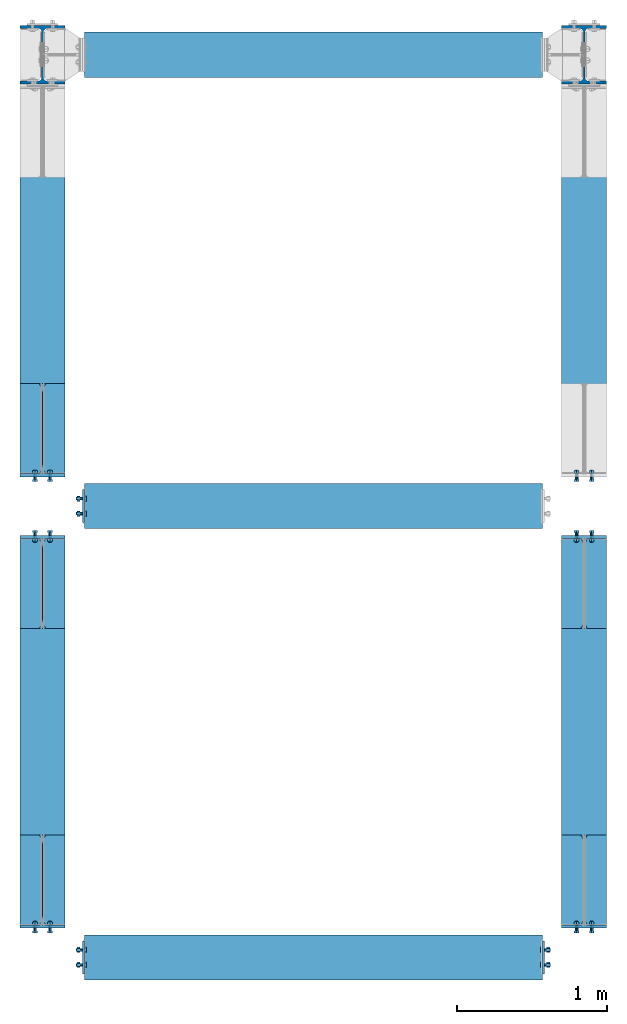
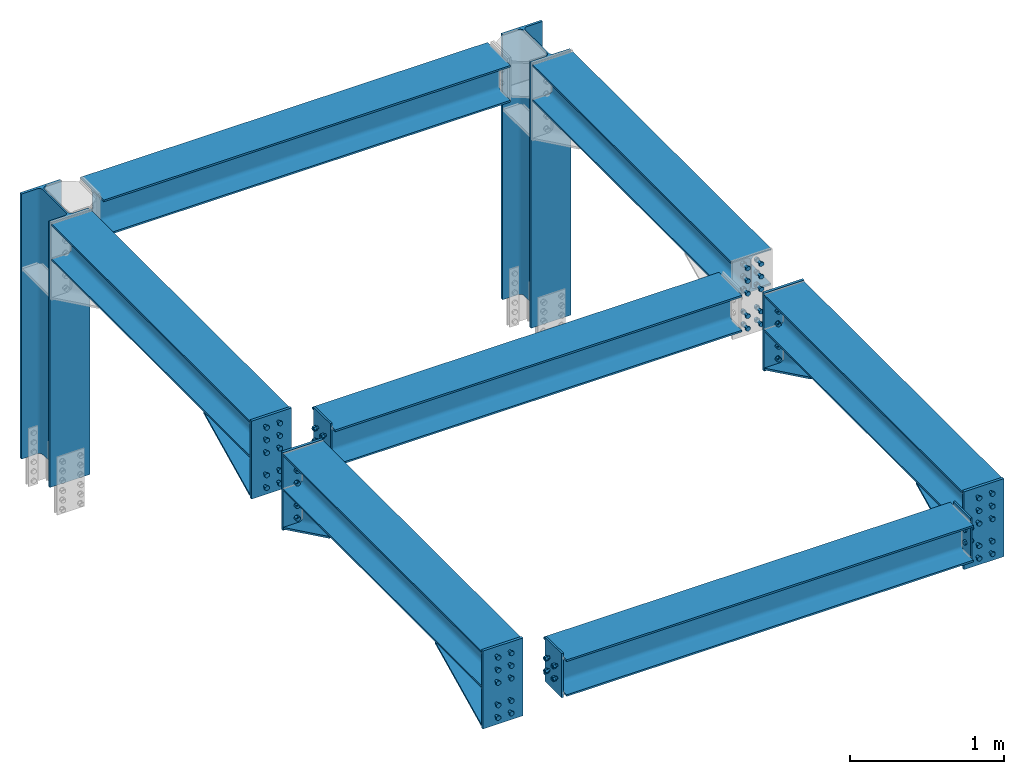
# One storey, part 1 of 11: 15 mechanical fasteners, 13 discrete accessories, 7 beams, 2 columns, 9 elements without a shape of their own.
"""IFC2X3 building model written with IfcOpenShell, lengths in millimetres."""

from ifc_helpers import new_model, si_unit, frame, origin_with_axes, origin_2d_with_axis, place, context, subcontext, project, spatial, polyline, circle, i_section, outline, extrude, clip, halfspace, source, transform, mapped, material, type_object, element, aggregate, save


model = new_model("IFC2X3")

# Units and contexts
model_context = context("Model", 3, precision=1e-05, world=origin_with_axes())
body_context = subcontext(model_context, "Body", "Model", "MODEL_VIEW")
ifc_project = project(units=[si_unit("LENGTHUNIT", "METRE", prefix="MILLI"), si_unit("AREAUNIT", "SQUARE_METRE"), si_unit("VOLUMEUNIT", "CUBIC_METRE"), si_unit("MASSUNIT", "GRAM", prefix="KILO"), si_unit("TIMEUNIT", "SECOND"), si_unit("PLANEANGLEUNIT", "RADIAN"), si_unit("SOLIDANGLEUNIT", "STERADIAN"), si_unit("THERMODYNAMICTEMPERATUREUNIT", "DEGREE_CELSIUS"), si_unit("LUMINOUSINTENSITYUNIT", "LUMEN")], contexts=[model_context])

# Site, building, storey
site_placement = place(None, origin_with_axes())
site = spatial("IfcSite", under=ifc_project, at=site_placement, CompositionType="ELEMENT")
building_placement = place(site_placement, origin_with_axes())
building = spatial("IfcBuilding", under=site, at=building_placement, Name="Edificio", CompositionType="ELEMENT")
storey_placement = place(building_placement, frame((0.0, 0.0, 3600.0), z_axis=(0.0, 0.0, 1.0), x_axis=(1.0, 0.0, 0.0)))
storey = spatial("IfcBuildingStorey", under=building, at=storey_placement, Name="Livello 2", CompositionType="ELEMENT", Elevation=3600.0)

# Assembly, column
assembly_1_placement = place(storey_placement, origin_with_axes())
assembly_1 = element("IfcElementAssembly", 1, at=assembly_1_placement, inside=storey, Name="COLUMN", AssemblyPlace="NOTDEFINED", PredefinedType="RIGID_FRAME")
ifc_material_1 = material(Name="STEEL/S235JR")
column_type = type_object("IfcColumnType", Name="HEA400", PredefinedType="NOTDEFINED")
column_1_placement = place(assembly_1_placement, frame((0.0, 6000.0, 1502.11580360386), z_axis=(0.0, 0.0, 1.0), x_axis=(0.0, 1.0, 0.0)))
column_1 = element("IfcColumn", 2, at=column_1_placement, type_object=column_type, material=ifc_material_1, Name="COLUMN", ObjectType="HEA400", context=body_context, shape_type="Clipping", body=[
    clip(extrude(i_section(OverallWidth=300.0, OverallDepth=390.0, WebThickness=11.0, FlangeThickness=19.0, FilletRadius=27.0, at=origin_2d_with_axis()), frame((0.0, 0.0, 2097.88419639614), z_axis=(0.0, 0.0, -1.0), x_axis=(0.0, 1.0, 0.0)), (0.0, 0.0, 1.0), 2097.88), halfspace(frame((1000.0, 0.0, 0.0), z_axis=(0.0, 0.0, -1.0), x_axis=(0.0, 1.0, 0.0)), False)),
])
aggregate(assembly_1, [column_1])

assembly_2_placement = place(storey_placement, origin_with_axes())
assembly_2 = element("IfcElementAssembly", 3, at=assembly_2_placement, inside=storey, Name="COLUMN", AssemblyPlace="NOTDEFINED", PredefinedType="RIGID_FRAME")
column_2_placement = place(assembly_2_placement, frame((3600.0, 6000.0, 1502.11580360386), z_axis=(0.0, 0.0, 1.0), x_axis=(0.0, 1.0, 0.0)))
column_2 = element("IfcColumn", 4, at=column_2_placement, type_object=column_type, material=ifc_material_1, Name="COLUMN", ObjectType="HEA400", context=body_context, shape_type="Clipping", body=[
    clip(extrude(i_section(OverallWidth=300.0, OverallDepth=390.0, WebThickness=11.0, FlangeThickness=19.0, FilletRadius=27.0, at=origin_2d_with_axis()), frame((0.0, 0.0, 2097.88419639614), z_axis=(0.0, 0.0, -1.0), x_axis=(0.0, 1.0, 0.0)), (0.0, 0.0, 1.0), 2097.88), halfspace(frame((1000.0, 0.0, 0.0), z_axis=(0.0, 0.0, -1.0), x_axis=(0.0, 1.0, 0.0)), False)),
])
aggregate(assembly_2, [column_2])

# Assembly, beam
assembly_3_placement = place(storey_placement, origin_with_axes())
assembly_3 = element("IfcElementAssembly", 5, at=assembly_3_placement, inside=storey, Name="BEAM", AssemblyPlace="NOTDEFINED", PredefinedType="RIGID_FRAME")
beam_type = type_object("IfcBeamType", Name="HEA300", PredefinedType="NOTDEFINED")
beam_1_placement = place(assembly_3_placement, frame((0.0, 3000.0, 3455.0), z_axis=(0.0, 0.0, 1.0), x_axis=(0.0, -1.0, 0.0)))
beam_1 = element("IfcBeam", 6, at=beam_1_placement, type_object=beam_type, material=ifc_material_1, Name="BEAM", ObjectType="HEA300", context=body_context, shape_type="Clipping", body=[
    clip(clip(extrude(i_section(OverallWidth=300.0, OverallDepth=290.0, WebThickness=8.5, FlangeThickness=14.0, FilletRadius=27.0, at=origin_2d_with_axis()), frame((2785.0, 0.0, 0.0), z_axis=(-1.0, 0.0, 0.0), x_axis=(0.0, -1.0, 0.0)), (0.0, 0.0, 1.0), 2570.0), halfspace(frame((2785.0, 0.0, -145.0), z_axis=(-1.0, 0.0, 0.0), x_axis=(0.0, 1.0, 0.0)), True)), halfspace(frame((215.0, 0.0, -145.0), z_axis=(1.0, 0.0, 0.0), x_axis=(0.0, -1.0, 0.0)), True)),
])

assembly_4_placement = place(storey_placement, origin_with_axes())
assembly_4 = element("IfcElementAssembly", 7, at=assembly_4_placement, inside=storey, Name="BEAM", AssemblyPlace="NOTDEFINED", PredefinedType="RIGID_FRAME")
beam_2_placement = place(assembly_4_placement, frame((3600.0, 3000.0, 3455.0), z_axis=(0.0, 0.0, 1.0), x_axis=(0.0, -1.0, 0.0)))
beam_2 = element("IfcBeam", 8, at=beam_2_placement, type_object=beam_type, material=ifc_material_1, Name="BEAM", ObjectType="HEA300", context=body_context, shape_type="Clipping", body=[
    clip(clip(extrude(i_section(OverallWidth=300.0, OverallDepth=290.0, WebThickness=8.5, FlangeThickness=14.0, FilletRadius=27.0, at=origin_2d_with_axis()), frame((2785.0, 0.0, 0.0), z_axis=(-1.0, 0.0, 0.0), x_axis=(0.0, -1.0, 0.0)), (0.0, 0.0, 1.0), 2570.0), halfspace(frame((2785.0, 0.0, -145.0), z_axis=(-1.0, 0.0, 0.0), x_axis=(0.0, 1.0, 0.0)), True)), halfspace(frame((215.0, 0.0, -145.0), z_axis=(1.0, 0.0, 0.0), x_axis=(0.0, -1.0, 0.0)), True)),
])

assembly_5_placement = place(storey_placement, origin_with_axes())
assembly_5 = element("IfcElementAssembly", 9, at=assembly_5_placement, inside=storey, Name="BEAM", AssemblyPlace="NOTDEFINED", PredefinedType="RIGID_FRAME")
beam_3_placement = place(assembly_5_placement, frame((0.0, 6000.0, 3455.0), z_axis=(0.0, 0.0, 1.0), x_axis=(0.0, -1.0, 0.0)))
beam_3 = element("IfcBeam", 10, at=beam_3_placement, type_object=beam_type, material=ifc_material_1, Name="BEAM", ObjectType="HEA300", context=body_context, shape_type="Clipping", body=[
    clip(clip(extrude(i_section(OverallWidth=300.0, OverallDepth=290.0, WebThickness=8.5, FlangeThickness=14.0, FilletRadius=27.0, at=origin_2d_with_axis()), frame((2785.0, 0.0, 0.0), z_axis=(-1.0, 0.0, 0.0), x_axis=(0.0, -1.0, 0.0)), (0.0, 0.0, 1.0), 2570.0), halfspace(frame((2785.0, 0.0, -145.0), z_axis=(-1.0, 0.0, 0.0), x_axis=(0.0, 1.0, 0.0)), True)), halfspace(frame((215.0, 0.0, -145.0), z_axis=(1.0, 0.0, 0.0), x_axis=(0.0, -1.0, 0.0)), True)),
])

assembly_6_placement = place(storey_placement, origin_with_axes())
assembly_6 = element("IfcElementAssembly", 11, at=assembly_6_placement, inside=storey, Name="BEAM", AssemblyPlace="NOTDEFINED", PredefinedType="RIGID_FRAME")
beam_4_placement = place(assembly_6_placement, frame((3600.0, 6000.0, 3455.0), z_axis=(0.0, 0.0, 1.0), x_axis=(0.0, -1.0, 0.0)))
beam_4 = element("IfcBeam", 12, at=beam_4_placement, type_object=beam_type, material=ifc_material_1, Name="BEAM", ObjectType="HEA300", context=body_context, shape_type="Clipping", body=[
    clip(clip(extrude(i_section(OverallWidth=300.0, OverallDepth=290.0, WebThickness=8.5, FlangeThickness=14.0, FilletRadius=27.0, at=origin_2d_with_axis()), frame((2785.0, 0.0, 0.0), z_axis=(-1.0, 0.0, 0.0), x_axis=(0.0, -1.0, 0.0)), (0.0, 0.0, 1.0), 2570.0), halfspace(frame((2785.0, 0.0, -145.0), z_axis=(-1.0, 0.0, 0.0), x_axis=(0.0, 1.0, 0.0)), True)), halfspace(frame((215.0, 0.0, -145.0), z_axis=(1.0, 0.0, 0.0), x_axis=(0.0, -1.0, 0.0)), True)),
])

assembly_7_placement = place(storey_placement, origin_with_axes())
assembly_7 = element("IfcElementAssembly", 13, at=assembly_7_placement, inside=storey, Name="BEAM", AssemblyPlace="NOTDEFINED", PredefinedType="RIGID_FRAME")
beam_5_placement = place(assembly_7_placement, frame((0.0, 6000.0, 3455.0), z_axis=(0.0, 0.0, 1.0), x_axis=(1.0, 0.0, 0.0)))
beam_5 = element("IfcBeam", 14, at=beam_5_placement, type_object=beam_type, material=ifc_material_1, Name="BEAM", ObjectType="HEA300", context=body_context, shape_type="Clipping", body=[
    clip(clip(extrude(i_section(OverallWidth=300.0, OverallDepth=290.0, WebThickness=8.5, FlangeThickness=14.0, FilletRadius=27.0, at=origin_2d_with_axis()), frame((3322.0, 0.0, 0.0), z_axis=(-1.0, 0.0, 0.0), x_axis=(0.0, -1.0, 0.0)), (0.0, 0.0, 1.0), 3044.0), halfspace(frame((3322.0, -150.0, 0.0), z_axis=(1.0, 0.0, 0.0), x_axis=(0.0, 0.0, 1.0)), False)), halfspace(frame((278.0, 150.0, 0.0), z_axis=(-1.0, 0.0, 0.0), x_axis=(0.0, 0.0, 1.0)), False)),
])
aggregate(assembly_7, [beam_5])

assembly_8_placement = place(storey_placement, origin_with_axes())
assembly_8 = element("IfcElementAssembly", 15, at=assembly_8_placement, inside=storey, Name="BEAM", AssemblyPlace="NOTDEFINED", PredefinedType="RIGID_FRAME")
beam_6_placement = place(assembly_8_placement, frame((0.0, 3000.0, 3455.0), z_axis=(0.0, 0.0, 1.0), x_axis=(1.0, 0.0, 0.0)))
beam_6 = element("IfcBeam", 16, at=beam_6_placement, type_object=beam_type, material=ifc_material_1, Name="BEAM", ObjectType="HEA300", context=body_context, shape_type="Clipping", body=[
    clip(clip(extrude(i_section(OverallWidth=300.0, OverallDepth=290.0, WebThickness=8.5, FlangeThickness=14.0, FilletRadius=27.0, at=origin_2d_with_axis()), frame((3322.0, 0.0, 0.0), z_axis=(-1.0, 0.0, 0.0), x_axis=(0.0, -1.0, 0.0)), (0.0, 0.0, 1.0), 3044.0), halfspace(frame((3322.0, -150.0, 0.0), z_axis=(1.0, 0.0, 0.0), x_axis=(0.0, 0.0, 1.0)), False)), halfspace(frame((278.0, 150.0, 0.0), z_axis=(-1.0, 0.0, 0.0), x_axis=(0.0, 0.0, 1.0)), False)),
])

assembly_9_placement = place(storey_placement, origin_with_axes())
assembly_9 = element("IfcElementAssembly", 17, at=assembly_9_placement, inside=storey, Name="BEAM", AssemblyPlace="NOTDEFINED", PredefinedType="RIGID_FRAME")
beam_7_placement = place(assembly_9_placement, frame((0.0, 0.0, 3455.0), z_axis=(0.0, 0.0, 1.0), x_axis=(1.0, 0.0, 0.0)))
beam_7 = element("IfcBeam", 18, at=beam_7_placement, type_object=beam_type, material=ifc_material_1, Name="BEAM", ObjectType="HEA300", context=body_context, shape_type="Clipping", body=[
    clip(clip(extrude(i_section(OverallWidth=300.0, OverallDepth=290.0, WebThickness=8.5, FlangeThickness=14.0, FilletRadius=27.0, at=origin_2d_with_axis()), frame((3322.0, 0.0, 0.0), z_axis=(-1.0, 0.0, 0.0), x_axis=(0.0, -1.0, 0.0)), (0.0, 0.0, 1.0), 3044.0), halfspace(frame((3322.0, -150.0, 0.0), z_axis=(1.0, 0.0, 0.0), x_axis=(0.0, 0.0, 1.0)), False)), halfspace(frame((278.0, 150.0, 0.0), z_axis=(-1.0, 0.0, 0.0), x_axis=(0.0, 0.0, 1.0)), False)),
])

# Discrete accessory
discrete_accessory_type_1 = type_object("IfcDiscreteAccessoryType", Name="PIATTO")
discrete_accessory_1_placement = place(assembly_4_placement, frame((3600.0, 2794.99999999989, 2993.20494914494), z_axis=(0.0, -1.0, 0.0), x_axis=(0.0, 0.0, 1.0)))
discrete_accessory_1 = element("IfcDiscreteAccessory", 19, at=discrete_accessory_1_placement, type_object=discrete_accessory_type_1, material=ifc_material_1, Name="PIATTO", context=body_context, shape_type="SweptSolid", body=[
    extrude(outline(polyline([(0.0, 150.0), (616.795050854866, 150.0), (616.795050854866, -150.0), (0.0, -150.0), (0.0, 150.0)])), frame((0.0, 0.0, -10.0), z_axis=(0.0, 0.0, 1.0), x_axis=(1.0, 0.0, 0.0)), (0.0, 0.0, 1.0), 20.0),
])

discrete_accessory_2_placement = place(assembly_5_placement, frame((0.0, 3205.0000000001, 2993.20494914494), z_axis=(0.0, 1.0, 0.0), x_axis=(0.0, 0.0, 1.0)))
discrete_accessory_2 = element("IfcDiscreteAccessory", 20, at=discrete_accessory_2_placement, type_object=discrete_accessory_type_1, material=ifc_material_1, Name="PIATTO", context=body_context, shape_type="SweptSolid", body=[
    extrude(outline(polyline([(0.0, -150.0), (0.0, 150.0), (616.795050854866, 150.0), (616.795050854866, -150.0), (0.0, -150.0)])), frame((0.0, 0.0, -10.0), z_axis=(0.0, 0.0, 1.0), x_axis=(1.0, 0.0, 0.0)), (0.0, 0.0, 1.0), 20.0),
])

discrete_accessory_3_placement = place(assembly_3_placement, frame((0.0, 2794.99999999989, 2993.20494914494), z_axis=(0.0, -1.0, 0.0), x_axis=(0.0, 0.0, 1.0)))
discrete_accessory_3 = element("IfcDiscreteAccessory", 21, at=discrete_accessory_3_placement, type_object=discrete_accessory_type_1, material=ifc_material_1, Name="PIATTO", context=body_context, shape_type="SweptSolid", body=[
    extrude(outline(polyline([(0.0, 150.0), (616.795050854866, 150.0), (616.795050854866, -150.0), (0.0, -150.0), (0.0, 150.0)])), frame((0.0, 0.0, -10.0), z_axis=(0.0, 0.0, 1.0), x_axis=(1.0, 0.0, 0.0)), (0.0, 0.0, 1.0), 20.0),
])

discrete_accessory_4_placement = place(assembly_4_placement, frame((3600.0, 204.99999999962, 2993.20494914513), z_axis=(0.0, 1.0, 0.0), x_axis=(0.0, 0.0, 1.0)))
discrete_accessory_4 = element("IfcDiscreteAccessory", 22, at=discrete_accessory_4_placement, type_object=discrete_accessory_type_1, material=ifc_material_1, Name="PIATTO", context=body_context, shape_type="SweptSolid", body=[
    extrude(outline(polyline([(0.0, -150.0), (0.0, 150.0), (616.795050854866, 150.0), (616.795050854866, -150.0), (0.0, -150.0)])), frame((0.0, 0.0, -10.0), z_axis=(0.0, 0.0, 1.0), x_axis=(1.0, 0.0, 0.0)), (0.0, 0.0, 1.0), 20.0),
])

discrete_accessory_5_placement = place(assembly_3_placement, frame((0.0, 204.99999999962, 2993.20494914513), z_axis=(0.0, 1.0, 0.0), x_axis=(0.0, 0.0, 1.0)))
discrete_accessory_5 = element("IfcDiscreteAccessory", 23, at=discrete_accessory_5_placement, type_object=discrete_accessory_type_1, material=ifc_material_1, Name="PIATTO", context=body_context, shape_type="SweptSolid", body=[
    extrude(outline(polyline([(0.0, -150.0), (0.0, 150.0), (616.795050854866, 150.0), (616.795050854866, -150.0), (0.0, -150.0)])), frame((0.0, 0.0, -10.0), z_axis=(0.0, 0.0, 1.0), x_axis=(1.0, 0.0, 0.0)), (0.0, 0.0, 1.0), 20.0),
])

# Mechanical fastener
ifc_material_2 = material(Name="HR")
discrete_accessory_type_2 = type_object("IfcDiscreteAccessoryType", Name="Bolt assembly")
shared_shape_1 = source(origin_with_axes(), body_context, "Body", "SweptSolid", [
    extrude(circle(Radius=11.0, at=origin_2d_with_axis()), frame((0.0, 13.9, 0.0), z_axis=(0.0, 1.0, 0.0), x_axis=(1.0, 0.0, 0.0)), (0.0, 0.0, 1.0), 14.1),
    extrude(circle(Radius=11.0, at=origin_2d_with_axis()), frame((0.0, 0.1, 0.0), z_axis=(0.0, 1.0, 0.0), x_axis=(1.0, 0.0, 0.0)), (0.0, 0.0, 1.0), 14.0),
    extrude(outline(polyline([(18.47520861408, 0.0), (9.23760430704, 16.0000000000023), (-9.23760430704, 16.0000000000023), (-18.47520861408, 0.0), (-9.23760430704, -16.0000000000023), (9.23760430704, -16.0000000000023), (18.47520861408, 0.0)])), frame((0.0, -12.5, 0.0), z_axis=(0.0, 1.0, 0.0), x_axis=(1.0, 0.0, 0.0)), (0.0, 0.0, 1.0), 12.5),
    extrude(circle(Radius=10.0, at=origin_2d_with_axis()), frame((0.0, 0.0, 0.0), z_axis=(0.0, 1.0, 0.0), x_axis=(1.0, 0.0, 0.0)), (0.0, 0.0, 1.0), 55.0),
    extrude(circle(Radius=18.5, at=origin_2d_with_axis()), frame((0.0, 28.0, 0.0), z_axis=(0.0, 1.0, 0.0), x_axis=(1.0, 0.0, 0.0)), (0.0, 0.0, 1.0), 4.0),
    extrude(outline(polyline([(18.47520861408, 0.0), (9.23760430704, 16.0000000000023), (-9.23760430704, 16.0000000000023), (-18.47520861408, 0.0), (-9.23760430704, -16.0000000000023), (9.23760430704, -16.0000000000023), (18.47520861408, 0.0)])), frame((0.0, 32.0, 0.0), z_axis=(0.0, 1.0, 0.0), x_axis=(1.0, 0.0, 0.0)), (0.0, 0.0, 1.0), 18.0),
])
mechanical_fastener_1_placement = place(assembly_8_placement, frame((278.0, 2950.0, 3405.0), z_axis=(0.0, 0.0, 1.0), x_axis=(0.0, 1.0, 0.0)))
mechanical_fastener_1 = element("IfcMechanicalFastener", 24, at=mechanical_fastener_1_placement, type_object=discrete_accessory_type_2, material=ifc_material_2, Name="Bolt assembly", NominalDiameter=20.0, NominalLength=55.0, context=body_context, shape_type="MappedRepresentation", body=[
    mapped(shared_shape_1, transform((0.0, 0.0, 0.0))),
    mapped(shared_shape_1, transform((100.0, 0.0, 0.0))),
    mapped(shared_shape_1, transform((0.0, 0.0, 100.0))),
    mapped(shared_shape_1, transform((100.0, 0.0, 100.0))),
])

mechanical_fastener_2_placement = place(assembly_9_placement, frame((3322.0, 50.0, 3405.0), z_axis=(0.0, 0.0, 1.0), x_axis=(0.0, -1.0, 0.0)))
mechanical_fastener_2 = element("IfcMechanicalFastener", 25, at=mechanical_fastener_2_placement, type_object=discrete_accessory_type_2, material=ifc_material_2, Name="Bolt assembly", NominalDiameter=20.0, NominalLength=55.0, context=body_context, shape_type="MappedRepresentation", body=[
    mapped(shared_shape_1, transform((0.0, 0.0, 0.0))),
    mapped(shared_shape_1, transform((100.0, 0.0, 0.0))),
    mapped(shared_shape_1, transform((0.0, 0.0, 100.0))),
    mapped(shared_shape_1, transform((100.0, 0.0, 100.0))),
])

mechanical_fastener_3_placement = place(assembly_9_placement, frame((278.0, -50.0, 3405.0), z_axis=(0.0, 0.0, 1.0), x_axis=(0.0, 1.0, 0.0)))
mechanical_fastener_3 = element("IfcMechanicalFastener", 26, at=mechanical_fastener_3_placement, type_object=discrete_accessory_type_2, material=ifc_material_2, Name="Bolt assembly", NominalDiameter=20.0, NominalLength=55.0, context=body_context, shape_type="MappedRepresentation", body=[
    mapped(shared_shape_1, transform((0.0, 0.0, 0.0))),
    mapped(shared_shape_1, transform((100.0, 0.0, 0.0))),
    mapped(shared_shape_1, transform((0.0, 0.0, 100.0))),
    mapped(shared_shape_1, transform((100.0, 0.0, 100.0))),
])

# Discrete accessory
discrete_accessory_type_3 = type_object("IfcDiscreteAccessoryType", Name="ENDPLATE_2")
discrete_accessory_6_placement = place(assembly_8_placement, frame((271.0, 3110.0, 3280.0), z_axis=(1.0, 0.0, 0.0), x_axis=(0.0, 0.0, 1.0)))
discrete_accessory_6 = element("IfcDiscreteAccessory", 27, at=discrete_accessory_6_placement, type_object=discrete_accessory_type_3, material=ifc_material_1, Name="ENDPLATE_2", context=body_context, shape_type="SweptSolid", body=[
    extrude(outline(polyline([(0.0, 0.0), (350.0, 0.0), (350.0, 220.0), (0.0, 220.0), (0.0, 0.0)])), frame((0.0, 0.0, -7.0), z_axis=(0.0, 0.0, 1.0), x_axis=(1.0, 0.0, 0.0)), (0.0, 0.0, 1.0), 14.0),
])

aggregate(assembly_8, [mechanical_fastener_1, discrete_accessory_6, beam_6])

discrete_accessory_7_placement = place(assembly_9_placement, frame((3329.0, -110.0, 3280.0), z_axis=(-1.0, 0.0, 0.0), x_axis=(0.0, 0.0, 1.0)))
discrete_accessory_7 = element("IfcDiscreteAccessory", 28, at=discrete_accessory_7_placement, type_object=discrete_accessory_type_3, material=ifc_material_1, Name="ENDPLATE_2", context=body_context, shape_type="SweptSolid", body=[
    extrude(outline(polyline([(0.0, 0.0), (350.0, 0.0), (350.0, 220.0), (0.0, 220.0), (0.0, 0.0)])), frame((0.0, 0.0, -7.0), z_axis=(0.0, 0.0, 1.0), x_axis=(1.0, 0.0, 0.0)), (0.0, 0.0, 1.0), 14.0),
])

discrete_accessory_8_placement = place(assembly_9_placement, frame((271.0, 110.0, 3280.0), z_axis=(1.0, 0.0, 0.0), x_axis=(0.0, 0.0, 1.0)))
discrete_accessory_8 = element("IfcDiscreteAccessory", 29, at=discrete_accessory_8_placement, type_object=discrete_accessory_type_3, material=ifc_material_1, Name="ENDPLATE_2", context=body_context, shape_type="SweptSolid", body=[
    extrude(outline(polyline([(0.0, 0.0), (350.0, 0.0), (350.0, 220.0), (0.0, 220.0), (0.0, 0.0)])), frame((0.0, 0.0, -7.0), z_axis=(0.0, 0.0, 1.0), x_axis=(1.0, 0.0, 0.0)), (0.0, 0.0, 1.0), 14.0),
])

aggregate(assembly_9, [mechanical_fastener_2, discrete_accessory_7, mechanical_fastener_3, discrete_accessory_8, beam_7])

# Mechanical fastener
shared_shape_2 = source(origin_with_axes(), body_context, "Body", "SweptSolid", [
    extrude(circle(Radius=11.0, at=origin_2d_with_axis()), frame((0.0, -19.9000000006085, 0.0), z_axis=(0.0, 1.0, 0.0), x_axis=(1.0, 0.0, 0.0)), (0.0, 0.0, 1.0), 19.0),
    extrude(circle(Radius=11.0, at=origin_2d_with_axis()), frame((0.0, -1.10000000013006, 0.0), z_axis=(0.0, 1.0, 0.0), x_axis=(1.0, 0.0, 0.0)), (0.0, 0.0, 1.0), 20.1),
    extrude(outline(polyline([(18.47520861408, 0.0), (9.23760430704, 16.0000000000023), (-9.23760430704, 16.0000000000023), (-18.47520861408, 0.0), (-9.23760430704, -16.0000000000023), (9.23760430704, -16.0000000000023), (18.47520861408, 0.0)])), frame((0.0, -32.5000000006085, 0.0), z_axis=(0.0, 1.0, 0.0), x_axis=(1.0, 0.0, 0.0)), (0.0, 0.0, 1.0), 12.5),
    extrude(circle(Radius=10.0, at=origin_2d_with_axis()), frame((0.0, -20.0000000006085, 0.0), z_axis=(0.0, 1.0, 0.0), x_axis=(1.0, 0.0, 0.0)), (0.0, 0.0, 1.0), 65.0),
    extrude(circle(Radius=18.5, at=origin_2d_with_axis()), frame((0.0, 18.9999999998699, 0.0), z_axis=(0.0, 1.0, 0.0), x_axis=(1.0, 0.0, 0.0)), (0.0, 0.0, 1.0), 4.0),
    extrude(outline(polyline([(18.47520861408, 0.0), (9.23760430704, 16.0000000000023), (-9.23760430704, 16.0000000000023), (-18.47520861408, 0.0), (-9.23760430704, -16.0000000000023), (9.23760430704, -16.0000000000023), (18.47520861408, 0.0)])), frame((0.0, 22.9999999998699, 0.0), z_axis=(0.0, 1.0, 0.0), x_axis=(1.0, 0.0, 0.0)), (0.0, 0.0, 1.0), 18.0),
])
mechanical_fastener_4_placement = place(assembly_6_placement, frame((3600.0, 3196.00000000015, 3063.20494914494), z_axis=(-1.0, 0.0, 0.0), x_axis=(0.0, 0.0, 1.0)))
mechanical_fastener_4 = element("IfcMechanicalFastener", 30, at=mechanical_fastener_4_placement, type_object=discrete_accessory_type_2, material=ifc_material_2, Name="Bolt assembly", NominalDiameter=20.0, NominalLength=65.0, context=body_context, shape_type="MappedRepresentation", body=[
    mapped(shared_shape_2, transform((0.0, 0.0, -50.0))),
    mapped(shared_shape_2, transform((0.0, 0.0, 50.0))),
    mapped(shared_shape_2, transform((100.0, 0.0, -50.0))),
    mapped(shared_shape_2, transform((100.0, 0.0, 50.0))),
])

mechanical_fastener_5_placement = place(assembly_6_placement, frame((3600.0, 3196.00000000015, 3540.0), z_axis=(1.0, 0.0, 0.0), x_axis=(0.0, 0.0, -1.0)))
mechanical_fastener_5 = element("IfcMechanicalFastener", 31, at=mechanical_fastener_5_placement, type_object=discrete_accessory_type_2, material=ifc_material_2, Name="Bolt assembly", NominalDiameter=20.0, NominalLength=65.0, context=body_context, shape_type="MappedRepresentation", body=[
    mapped(shared_shape_2, transform((0.0, 0.0, -50.0))),
    mapped(shared_shape_2, transform((0.0, 0.0, 50.0))),
    mapped(shared_shape_2, transform((100.0, 0.0, -50.0))),
    mapped(shared_shape_2, transform((100.0, 0.0, 50.0))),
    mapped(shared_shape_2, transform((200.0, 0.0, -50.0))),
    mapped(shared_shape_2, transform((200.0, 0.0, 50.0))),
])

aggregate(assembly_6, [mechanical_fastener_4, mechanical_fastener_5, beam_4])

mechanical_fastener_6_placement = place(assembly_4_placement, frame((3600.0, 2803.99999999985, 3063.20494914494), z_axis=(1.0, 0.0, 0.0), x_axis=(0.0, 0.0, 1.0)))
mechanical_fastener_6 = element("IfcMechanicalFastener", 32, at=mechanical_fastener_6_placement, type_object=discrete_accessory_type_2, material=ifc_material_2, Name="Bolt assembly", NominalDiameter=20.0, NominalLength=65.0, context=body_context, shape_type="MappedRepresentation", body=[
    mapped(shared_shape_2, transform((0.0, 0.0, -50.0))),
    mapped(shared_shape_2, transform((0.0, 0.0, 50.0))),
    mapped(shared_shape_2, transform((100.0, 0.0, -50.0))),
    mapped(shared_shape_2, transform((100.0, 0.0, 50.0))),
])

mechanical_fastener_7_placement = place(assembly_4_placement, frame((3600.0, 2803.99999999985, 3540.0), z_axis=(-1.0, 0.0, 0.0), x_axis=(0.0, 0.0, -1.0)))
mechanical_fastener_7 = element("IfcMechanicalFastener", 33, at=mechanical_fastener_7_placement, type_object=discrete_accessory_type_2, material=ifc_material_2, Name="Bolt assembly", NominalDiameter=20.0, NominalLength=65.0, context=body_context, shape_type="MappedRepresentation", body=[
    mapped(shared_shape_2, transform((0.0, 0.0, -50.0))),
    mapped(shared_shape_2, transform((0.0, 0.0, 50.0))),
    mapped(shared_shape_2, transform((100.0, 0.0, -50.0))),
    mapped(shared_shape_2, transform((100.0, 0.0, 50.0))),
    mapped(shared_shape_2, transform((200.0, 0.0, -50.0))),
    mapped(shared_shape_2, transform((200.0, 0.0, 50.0))),
])

mechanical_fastener_8_placement = place(assembly_5_placement, frame((0.0, 3196.00000000015, 3063.20494914494), z_axis=(-1.0, 0.0, 0.0), x_axis=(0.0, 0.0, 1.0)))
mechanical_fastener_8 = element("IfcMechanicalFastener", 34, at=mechanical_fastener_8_placement, type_object=discrete_accessory_type_2, material=ifc_material_2, Name="Bolt assembly", NominalDiameter=20.0, NominalLength=65.0, context=body_context, shape_type="MappedRepresentation", body=[
    mapped(shared_shape_2, transform((0.0, 0.0, -50.0))),
    mapped(shared_shape_2, transform((0.0, 0.0, 50.0))),
    mapped(shared_shape_2, transform((100.0, 0.0, -50.0))),
    mapped(shared_shape_2, transform((100.0, 0.0, 50.0))),
])

mechanical_fastener_9_placement = place(assembly_5_placement, frame((0.0, 3196.00000000015, 3540.0), z_axis=(1.0, 0.0, 0.0), x_axis=(0.0, 0.0, -1.0)))
mechanical_fastener_9 = element("IfcMechanicalFastener", 35, at=mechanical_fastener_9_placement, type_object=discrete_accessory_type_2, material=ifc_material_2, Name="Bolt assembly", NominalDiameter=20.0, NominalLength=65.0, context=body_context, shape_type="MappedRepresentation", body=[
    mapped(shared_shape_2, transform((0.0, 0.0, -50.0))),
    mapped(shared_shape_2, transform((0.0, 0.0, 50.0))),
    mapped(shared_shape_2, transform((100.0, 0.0, -50.0))),
    mapped(shared_shape_2, transform((100.0, 0.0, 50.0))),
    mapped(shared_shape_2, transform((200.0, 0.0, -50.0))),
    mapped(shared_shape_2, transform((200.0, 0.0, 50.0))),
])

mechanical_fastener_10_placement = place(assembly_3_placement, frame((0.0, 2803.99999999985, 3063.20494914494), z_axis=(1.0, 0.0, 0.0), x_axis=(0.0, 0.0, 1.0)))
mechanical_fastener_10 = element("IfcMechanicalFastener", 36, at=mechanical_fastener_10_placement, type_object=discrete_accessory_type_2, material=ifc_material_2, Name="Bolt assembly", NominalDiameter=20.0, NominalLength=65.0, context=body_context, shape_type="MappedRepresentation", body=[
    mapped(shared_shape_2, transform((0.0, 0.0, -50.0))),
    mapped(shared_shape_2, transform((0.0, 0.0, 50.0))),
    mapped(shared_shape_2, transform((100.0, 0.0, -50.0))),
    mapped(shared_shape_2, transform((100.0, 0.0, 50.0))),
])

mechanical_fastener_11_placement = place(assembly_3_placement, frame((0.0, 2803.99999999985, 3540.0), z_axis=(-1.0, 0.0, 0.0), x_axis=(0.0, 0.0, -1.0)))
mechanical_fastener_11 = element("IfcMechanicalFastener", 37, at=mechanical_fastener_11_placement, type_object=discrete_accessory_type_2, material=ifc_material_2, Name="Bolt assembly", NominalDiameter=20.0, NominalLength=65.0, context=body_context, shape_type="MappedRepresentation", body=[
    mapped(shared_shape_2, transform((0.0, 0.0, -50.0))),
    mapped(shared_shape_2, transform((0.0, 0.0, 50.0))),
    mapped(shared_shape_2, transform((100.0, 0.0, -50.0))),
    mapped(shared_shape_2, transform((100.0, 0.0, 50.0))),
    mapped(shared_shape_2, transform((200.0, 0.0, -50.0))),
    mapped(shared_shape_2, transform((200.0, 0.0, 50.0))),
])

mechanical_fastener_12_placement = place(assembly_4_placement, frame((3600.0, 195.999999999778, 3063.20494914513), z_axis=(-1.0, 0.0, 0.0), x_axis=(0.0, 0.0, 1.0)))
mechanical_fastener_12 = element("IfcMechanicalFastener", 38, at=mechanical_fastener_12_placement, type_object=discrete_accessory_type_2, material=ifc_material_2, Name="Bolt assembly", NominalDiameter=20.0, NominalLength=65.0, context=body_context, shape_type="MappedRepresentation", body=[
    mapped(shared_shape_2, transform((0.0, 0.0, -50.0))),
    mapped(shared_shape_2, transform((0.0, 0.0, 50.0))),
    mapped(shared_shape_2, transform((100.0, 0.0, -50.0))),
    mapped(shared_shape_2, transform((100.0, 0.0, 50.0))),
])

mechanical_fastener_13_placement = place(assembly_4_placement, frame((3600.0, 195.999999999998, 3540.00000000001), z_axis=(1.0, 0.0, 0.0), x_axis=(0.0, 0.0, -1.0)))
mechanical_fastener_13 = element("IfcMechanicalFastener", 39, at=mechanical_fastener_13_placement, type_object=discrete_accessory_type_2, material=ifc_material_2, Name="Bolt assembly", NominalDiameter=20.0, NominalLength=65.0, context=body_context, shape_type="MappedRepresentation", body=[
    mapped(shared_shape_2, transform((0.0, 0.0, -50.0))),
    mapped(shared_shape_2, transform((0.0, 0.0, 50.0))),
    mapped(shared_shape_2, transform((100.0, 0.0, -50.0))),
    mapped(shared_shape_2, transform((100.0, 0.0, 50.0))),
    mapped(shared_shape_2, transform((200.0, 0.0, -50.0))),
    mapped(shared_shape_2, transform((200.0, 0.0, 50.0))),
])

mechanical_fastener_14_placement = place(assembly_3_placement, frame((0.0, 195.999999999778, 3063.20494914513), z_axis=(-1.0, 0.0, 0.0), x_axis=(0.0, 0.0, 1.0)))
mechanical_fastener_14 = element("IfcMechanicalFastener", 40, at=mechanical_fastener_14_placement, type_object=discrete_accessory_type_2, material=ifc_material_2, Name="Bolt assembly", NominalDiameter=20.0, NominalLength=65.0, context=body_context, shape_type="MappedRepresentation", body=[
    mapped(shared_shape_2, transform((0.0, 0.0, -50.0))),
    mapped(shared_shape_2, transform((0.0, 0.0, 50.0))),
    mapped(shared_shape_2, transform((100.0, 0.0, -50.0))),
    mapped(shared_shape_2, transform((100.0, 0.0, 50.0))),
])

mechanical_fastener_15_placement = place(assembly_3_placement, frame((0.0, 195.999999999998, 3540.00000000001), z_axis=(1.0, 0.0, 0.0), x_axis=(0.0, 0.0, -1.0)))
mechanical_fastener_15 = element("IfcMechanicalFastener", 41, at=mechanical_fastener_15_placement, type_object=discrete_accessory_type_2, material=ifc_material_2, Name="Bolt assembly", NominalDiameter=20.0, NominalLength=65.0, context=body_context, shape_type="MappedRepresentation", body=[
    mapped(shared_shape_2, transform((0.0, 0.0, -50.0))),
    mapped(shared_shape_2, transform((0.0, 0.0, 50.0))),
    mapped(shared_shape_2, transform((100.0, 0.0, -50.0))),
    mapped(shared_shape_2, transform((100.0, 0.0, 50.0))),
    mapped(shared_shape_2, transform((200.0, 0.0, -50.0))),
    mapped(shared_shape_2, transform((200.0, 0.0, 50.0))),
])

# Discrete accessory
discrete_accessory_type_4 = type_object("IfcDiscreteAccessoryType")
discrete_accessory_9_placement = place(assembly_4_placement, frame((3599.99999999998, 2848.31666666672, 3133.65033895337), z_axis=(0.0, 0.436666666931657, 0.8996233778592), x_axis=(0.0, -0.8996233778592, 0.436666666931657)))
discrete_accessory_9 = element("IfcDiscreteAccessory", 42, at=discrete_accessory_9_placement, type_object=discrete_accessory_type_4, material=ifc_material_1, ObjectType="HEA300", context=body_context, shape_type="Clipping", body=[
    clip(clip(clip(clip(extrude(i_section(OverallWidth=300.0, OverallDepth=290.0, WebThickness=8.5, FlangeThickness=14.0, FilletRadius=27.0, at=origin_2d_with_axis()), frame((1079.68937216795, 0.0, 0.0), z_axis=(-1.0, 0.0, 0.0), x_axis=(0.0, -1.0, 0.0)), (0.0, 0.0, 1.0), 1351.67), halfspace(frame((105.124285258009, 150.0, 145.000000000002), z_axis=(0.436666666931658, 0.0, 0.8996233778592), x_axis=(0.8996233778592, 0.0, -0.436666666931658)), False)), halfspace(frame((6.79543622875235, 150.0, -144.999999999998), z_axis=(-1.0, 0.0, 0.0), x_axis=(0.0, 0.0, 1.0)), False)), halfspace(frame((666.945762685627, 4.18367562815547e-11, -145.000000196482), z_axis=(0.8996233778592, 0.0, -0.436666666931658), x_axis=(0.0, -1.0, 0.0)), False)), halfspace(frame((697.267172587419, 4.18367562815547e-11, 1291.51415739888), z_axis=(-0.8996233778592, 0.0, 0.436666666931657), x_axis=(0.0, -1.0, 0.0)), False)),
])

discrete_accessory_10_placement = place(assembly_5_placement, frame((-2.18776108340535e-11, 3151.68333333342, 3133.65033895337), z_axis=(0.0, -0.436666666931657, 0.8996233778592), x_axis=(0.0, 0.8996233778592, 0.436666666931657)))
discrete_accessory_10 = element("IfcDiscreteAccessory", 43, at=discrete_accessory_10_placement, type_object=discrete_accessory_type_4, material=ifc_material_1, ObjectType="HEA300", context=body_context, shape_type="Clipping", body=[
    clip(clip(clip(clip(extrude(i_section(OverallWidth=300.0, OverallDepth=290.0, WebThickness=8.5, FlangeThickness=14.0, FilletRadius=27.0, at=origin_2d_with_axis()), frame((1079.68937216795, 0.0, 0.0), z_axis=(-1.0, 0.0, 0.0), x_axis=(0.0, -1.0, 0.0)), (0.0, 0.0, 1.0), 1351.67), halfspace(frame((105.124285258009, 150.0, 145.000000000002), z_axis=(0.436666666931658, 0.0, 0.8996233778592), x_axis=(0.8996233778592, 0.0, -0.436666666931658)), False)), halfspace(frame((6.79543622875235, 150.0, -144.999999999998), z_axis=(-1.0, 0.0, 0.0), x_axis=(0.0, 0.0, 1.0)), False)), halfspace(frame((666.945762685627, 4.18367562815547e-11, -145.000000196482), z_axis=(0.8996233778592, 0.0, -0.436666666931658), x_axis=(0.0, -1.0, 0.0)), False)), halfspace(frame((697.267172587419, 4.18367562815547e-11, 1291.51415739888), z_axis=(-0.8996233778592, 0.0, 0.436666666931657), x_axis=(0.0, -1.0, 0.0)), False)),
])

aggregate(assembly_5, [mechanical_fastener_8, mechanical_fastener_9, discrete_accessory_2, discrete_accessory_10, beam_3])

discrete_accessory_11_placement = place(assembly_3_placement, frame((-1.93765004041779e-11, 2848.31666666674, 3133.65033895337), z_axis=(0.0, 0.436666666931657, 0.8996233778592), x_axis=(0.0, -0.8996233778592, 0.436666666931657)))
discrete_accessory_11 = element("IfcDiscreteAccessory", 44, at=discrete_accessory_11_placement, type_object=discrete_accessory_type_4, material=ifc_material_1, ObjectType="HEA300", context=body_context, shape_type="Clipping", body=[
    clip(clip(clip(clip(extrude(i_section(OverallWidth=300.0, OverallDepth=290.0, WebThickness=8.5, FlangeThickness=14.0, FilletRadius=27.0, at=origin_2d_with_axis()), frame((1079.68937216795, 0.0, 0.0), z_axis=(-1.0, 0.0, 0.0), x_axis=(0.0, -1.0, 0.0)), (0.0, 0.0, 1.0), 1351.67), halfspace(frame((105.124285258009, 150.0, 145.000000000002), z_axis=(0.436666666931658, 0.0, 0.8996233778592), x_axis=(0.8996233778592, 0.0, -0.436666666931658)), False)), halfspace(frame((6.79543622875235, 150.0, -144.999999999998), z_axis=(-1.0, 0.0, 0.0), x_axis=(0.0, 0.0, 1.0)), False)), halfspace(frame((666.945762685627, 4.18367562815547e-11, -145.000000196482), z_axis=(0.8996233778592, 0.0, -0.436666666931658), x_axis=(0.0, -1.0, 0.0)), False)), halfspace(frame((697.267172587419, 4.18367562815547e-11, 1291.51415739888), z_axis=(-0.8996233778592, 0.0, 0.436666666931657), x_axis=(0.0, -1.0, 0.0)), False)),
])

discrete_accessory_12_placement = place(assembly_4_placement, frame((3599.99999999999, 151.683333333325, 3133.65033895337), z_axis=(0.0, -0.436666666931657, 0.8996233778592), x_axis=(0.0, 0.8996233778592, 0.436666666931657)))
discrete_accessory_12 = element("IfcDiscreteAccessory", 45, at=discrete_accessory_12_placement, type_object=discrete_accessory_type_4, material=ifc_material_1, ObjectType="HEA300", context=body_context, shape_type="Clipping", body=[
    clip(clip(clip(clip(extrude(i_section(OverallWidth=300.0, OverallDepth=290.0, WebThickness=8.5, FlangeThickness=14.0, FilletRadius=27.0, at=origin_2d_with_axis()), frame((1079.68937216795, 0.0, 0.0), z_axis=(-1.0, 0.0, 0.0), x_axis=(0.0, -1.0, 0.0)), (0.0, 0.0, 1.0), 1351.67), halfspace(frame((105.124285258009, 150.0, 145.000000000002), z_axis=(0.436666666931658, 0.0, 0.8996233778592), x_axis=(0.8996233778592, 0.0, -0.436666666931658)), False)), halfspace(frame((6.79543622875235, 150.0, -144.999999999998), z_axis=(-1.0, 0.0, 0.0), x_axis=(0.0, 0.0, 1.0)), False)), halfspace(frame((666.945762685627, 4.18367562815547e-11, -145.000000196482), z_axis=(0.8996233778592, 0.0, -0.436666666931658), x_axis=(0.0, -1.0, 0.0)), False)), halfspace(frame((697.267172587419, 4.18367562815547e-11, 1291.51415739888), z_axis=(-0.8996233778592, 0.0, 0.436666666931657), x_axis=(0.0, -1.0, 0.0)), False)),
])

aggregate(assembly_4, [mechanical_fastener_6, mechanical_fastener_7, discrete_accessory_1, discrete_accessory_9, mechanical_fastener_12, mechanical_fastener_13, discrete_accessory_4, discrete_accessory_12, beam_2])

discrete_accessory_13_placement = place(assembly_3_placement, frame((-3.37507799486048e-12, 151.683333333347, 3133.65033895337), z_axis=(0.0, -0.436666666931657, 0.8996233778592), x_axis=(0.0, 0.8996233778592, 0.436666666931657)))
discrete_accessory_13 = element("IfcDiscreteAccessory", 46, at=discrete_accessory_13_placement, type_object=discrete_accessory_type_4, material=ifc_material_1, ObjectType="HEA300", context=body_context, shape_type="Clipping", body=[
    clip(clip(clip(clip(extrude(i_section(OverallWidth=300.0, OverallDepth=290.0, WebThickness=8.5, FlangeThickness=14.0, FilletRadius=27.0, at=origin_2d_with_axis()), frame((1079.68937216795, 0.0, 0.0), z_axis=(-1.0, 0.0, 0.0), x_axis=(0.0, -1.0, 0.0)), (0.0, 0.0, 1.0), 1351.67), halfspace(frame((105.124285258009, 150.0, 145.000000000002), z_axis=(0.436666666931658, 0.0, 0.8996233778592), x_axis=(0.8996233778592, 0.0, -0.436666666931658)), False)), halfspace(frame((6.79543622875235, 150.0, -144.999999999998), z_axis=(-1.0, 0.0, 0.0), x_axis=(0.0, 0.0, 1.0)), False)), halfspace(frame((666.945762685627, 4.18367562815547e-11, -145.000000196482), z_axis=(0.8996233778592, 0.0, -0.436666666931658), x_axis=(0.0, -1.0, 0.0)), False)), halfspace(frame((697.267172587419, 4.18367562815547e-11, 1291.51415739888), z_axis=(-0.8996233778592, 0.0, 0.436666666931657), x_axis=(0.0, -1.0, 0.0)), False)),
])

aggregate(assembly_3, [mechanical_fastener_10, mechanical_fastener_11, discrete_accessory_3, discrete_accessory_11, mechanical_fastener_14, mechanical_fastener_15, discrete_accessory_5, discrete_accessory_13, beam_1])

save(model, "model.ifc")
